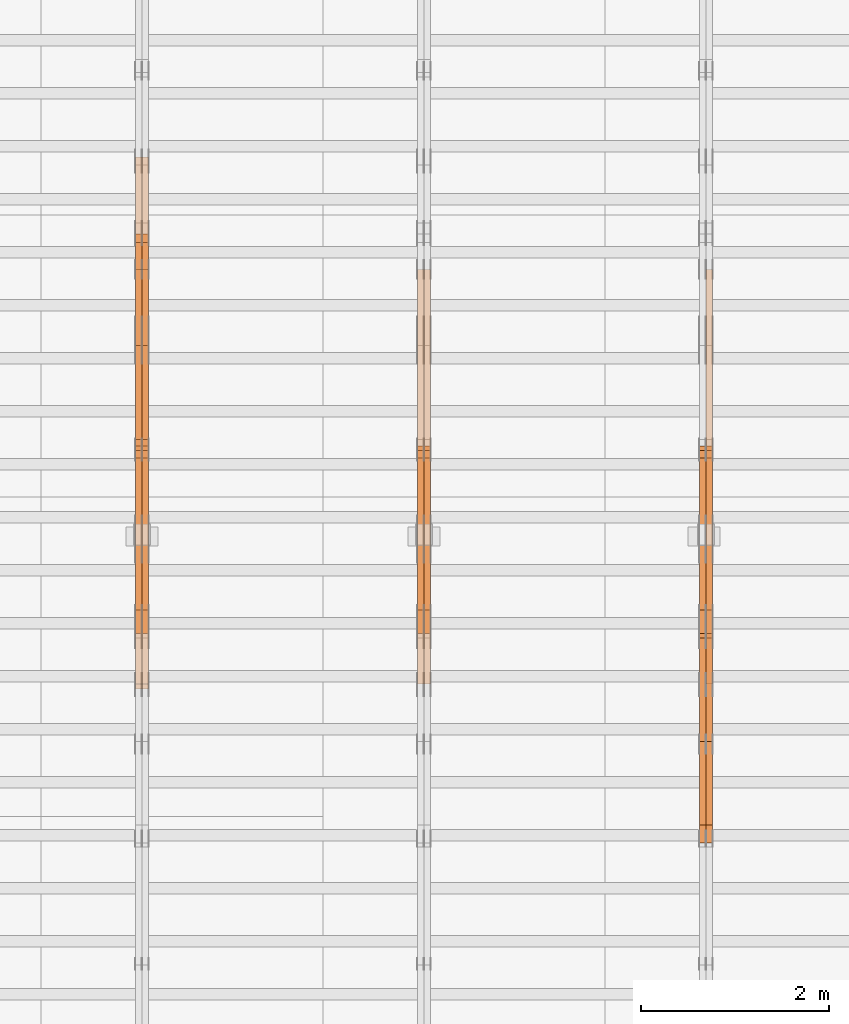
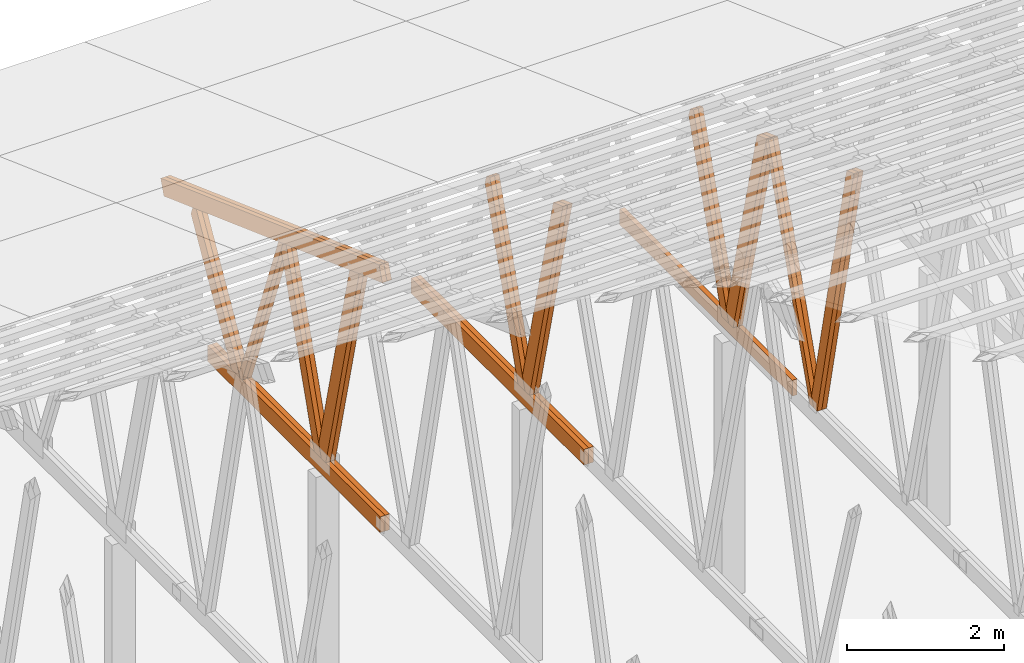
# One storey, part 41 of 189: 27 proxies.
"""IFC2X3 building model written with IfcOpenShell, lengths in millimetres."""

from ifc_helpers import new_model, entity, si_unit, converted_unit, derived_unit, direction, frame, origin, origin_2d_with_axis, place, context, subcontext, project, spatial, polyline, rectangle, outline, extrude, source, transform, mapped, material, type_object, type_shapes, element, save


model = new_model("IFC2X3")

# Units and contexts
model_context = context("Model", 3, precision=0.01, world=origin(), true_north=direction((6.12303176911189e-17, 1.0)))
body_context = subcontext(model_context, "Body", "Model", "MODEL_VIEW")
ifc_project = project(units=[si_unit("LENGTHUNIT", "METRE", prefix="MILLI"), si_unit("AREAUNIT", "SQUARE_METRE"), si_unit("VOLUMEUNIT", "CUBIC_METRE"), converted_unit("PLANEANGLEUNIT", "DEGREE", entity("IfcRatioMeasure", 0.0174532925199433), si_unit("PLANEANGLEUNIT", "RADIAN"), dimensions=[0, 0, 0, 0, 0, 0, 0]), si_unit("MASSUNIT", "GRAM", prefix="KILO"), derived_unit("MASSDENSITYUNIT", [(si_unit("MASSUNIT", "GRAM", prefix="KILO"), 1), (si_unit("LENGTHUNIT", "METRE"), -3)]), si_unit("TIMEUNIT", "SECOND"), si_unit("FREQUENCYUNIT", "HERTZ"), si_unit("THERMODYNAMICTEMPERATUREUNIT", "DEGREE_CELSIUS"), derived_unit("THERMALTRANSMITTANCEUNIT", [(si_unit("MASSUNIT", "GRAM", prefix="KILO"), 1), (si_unit("THERMODYNAMICTEMPERATUREUNIT", "KELVIN"), -1), (si_unit("TIMEUNIT", "SECOND"), -3)]), derived_unit("VOLUMETRICFLOWRATEUNIT", [(si_unit("LENGTHUNIT", "METRE"), 3), (si_unit("TIMEUNIT", "SECOND"), -1)]), si_unit("ELECTRICCURRENTUNIT", "AMPERE"), si_unit("ELECTRICVOLTAGEUNIT", "VOLT"), si_unit("POWERUNIT", "WATT"), si_unit("FORCEUNIT", "NEWTON"), si_unit("ILLUMINANCEUNIT", "LUX"), si_unit("LUMINOUSFLUXUNIT", "LUMEN"), si_unit("LUMINOUSINTENSITYUNIT", "CANDELA"), derived_unit("USERDEFINED", [(si_unit("MASSUNIT", "GRAM", prefix="KILO"), -1), (si_unit("LENGTHUNIT", "METRE"), -2), (si_unit("TIMEUNIT", "SECOND"), 3), (si_unit("LUMINOUSFLUXUNIT", "LUMEN"), 1)]), derived_unit("LINEARVELOCITYUNIT", [(si_unit("LENGTHUNIT", "METRE"), 1), (si_unit("TIMEUNIT", "SECOND"), -1)]), si_unit("PRESSUREUNIT", "PASCAL"), derived_unit("USERDEFINED", [(si_unit("LENGTHUNIT", "METRE"), -2), (si_unit("MASSUNIT", "GRAM", prefix="KILO"), 1), (si_unit("TIMEUNIT", "SECOND"), -2)])], contexts=[model_context])

# Site, building, storey
site_placement = place(None, origin())
site = spatial("IfcSite", under=ifc_project, at=site_placement, CompositionType="ELEMENT")
building_placement = place(site_placement, origin())
building = spatial("IfcBuilding", under=site, at=building_placement, CompositionType="ELEMENT")
storey_placement = place(building_placement, origin())
storey = spatial("IfcBuildingStorey", under=building, at=storey_placement, Name="Default", CompositionType="ELEMENT", Elevation=0.0)

# Proxies
ifc_material_1 = material(Name="IfcSurfaceStyle #162714")
building_element_proxy_type_1 = type_object("IfcBuildingElementProxyType", Name="T1-W3 162712", PredefinedType="NOTDEFINED", material=ifc_material_1)
shared_shape_1 = source(origin(), body_context, "Body", "SweptSolid", [
    extrude(outline(polyline([(-2517.58938959787, -85.0001104675026), (1625.445846867, -85.0001104675027), (1768.20563426494, 0.000209440697654673), (1749.48871563991, 85.0000057471538), (-2625.55080717397, 85.0000057471538), (-2517.58938959787, -85.0001104675026)])), frame((1768.2056683344, 85.0000547211315, 0.0), z_axis=(0.0, 0.0, 1.0), x_axis=(-1.0, 0.0, 0.0)), (0.0, 0.0, 1.0), 69.9999999999997),
])
type_shapes(building_element_proxy_type_1, [shared_shape_1])
proxy_1_placement = place(building_placement, frame((30300.0, 18415.3042863408, 226.720947016584), z_axis=(-1.0, 0.0, 0.0), x_axis=(0.0, -0.215047682154604, 0.976603550269982)))
element("IfcBuildingElementProxy", 1, at=proxy_1_placement, inside=storey, type_object=building_element_proxy_type_1, material=ifc_material_1, Name="T1-W3", context=body_context, shape_type="MappedRepresentation", body=[
    mapped(shared_shape_1, transform((0.0, 0.0, 0.0), scale=1.0)),
])
ifc_material_2 = material(Name="IfcSurfaceStyle #162648")
building_element_proxy_type_2 = type_object("IfcBuildingElementProxyType", Name="T1-W3 162646", PredefinedType="NOTDEFINED", material=ifc_material_2)
shared_shape_2 = source(origin(), body_context, "Body", "SweptSolid", [
    extrude(outline(polyline([(-2517.58938959787, -85.0001104675026), (1625.445846867, -85.0001104675027), (1768.20563426494, 0.000209440697654673), (1749.48871563991, 85.0000057471538), (-2625.55080717397, 85.0000057471538), (-2517.58938959787, -85.0001104675026)])), frame((1768.2056683344, 85.0000547211315, 0.0), z_axis=(0.0, 0.0, 1.0), x_axis=(-1.0, 0.0, 0.0)), (0.0, 0.0, 1.0), 69.9999999999997),
])
type_shapes(building_element_proxy_type_2, [shared_shape_2])
proxy_2_placement = place(building_placement, frame((30230.0, 18415.3042863408, 226.720947016584), z_axis=(-1.0, 0.0, 0.0), x_axis=(0.0, -0.215047682154604, 0.976603550269982)))
element("IfcBuildingElementProxy", 2, at=proxy_2_placement, inside=storey, type_object=building_element_proxy_type_2, material=ifc_material_2, Name="T1-W3", context=body_context, shape_type="MappedRepresentation", body=[
    mapped(shared_shape_2, transform((0.0, 0.0, 0.0), scale=1.0)),
])
ifc_material_3 = material(Name="IfcSurfaceStyle #162450")
building_element_proxy_type_3 = type_object("IfcBuildingElementProxyType", Name="T1-W7 162448", PredefinedType="NOTDEFINED", material=ifc_material_3)
shared_shape_3 = source(origin(), body_context, "Body", "SweptSolid", [
    extrude(outline(polyline([(-2189.6662270939, -47.5000140805343), (1475.30081553583, -47.5000140805343), (1473.93388518462, 0.00042343352179337), (1398.58463533215, 47.4998023637734), (-2158.15310895869, 47.4998023637734), (-2189.6662270939, -47.5000140805343)])), frame((1475.30081553583, 47.5004895824757, 0.0), z_axis=(0.0, 0.0, 1.0), x_axis=(-1.0, 0.0, 0.0)), (0.0, 0.0, 1.0), 69.9999999999998),
])
type_shapes(building_element_proxy_type_3, [shared_shape_3])
proxy_3_placement = place(building_placement, frame((30300.0, 19742.3819153401, 3693.66743808885), z_axis=(-1.0, 0.0, 0.0), x_axis=(0.0, -0.314845237923104, -0.949143021971475)))
element("IfcBuildingElementProxy", 3, at=proxy_3_placement, inside=storey, type_object=building_element_proxy_type_3, material=ifc_material_3, Name="T1-W7", context=body_context, shape_type="MappedRepresentation", body=[
    mapped(shared_shape_3, transform((0.0, 0.0, 0.0), scale=1.0)),
])
ifc_material_4 = material(Name="IfcSurfaceStyle #162384")
building_element_proxy_type_4 = type_object("IfcBuildingElementProxyType", Name="T1-W7 162382", PredefinedType="NOTDEFINED", material=ifc_material_4)
shared_shape_4 = source(origin(), body_context, "Body", "SweptSolid", [
    extrude(outline(polyline([(-2189.6662270939, -47.5000140805343), (1475.30081553583, -47.5000140805343), (1473.93388518462, 0.00042343352179337), (1398.58463533215, 47.4998023637734), (-2158.15310895869, 47.4998023637734), (-2189.6662270939, -47.5000140805343)])), frame((1475.30081553583, 47.5004895824757, 0.0), z_axis=(0.0, 0.0, 1.0), x_axis=(-1.0, 0.0, 0.0)), (0.0, 0.0, 1.0), 69.9999999999998),
])
type_shapes(building_element_proxy_type_4, [shared_shape_4])
proxy_4_placement = place(building_placement, frame((30230.0, 19742.3819153401, 3693.66743808885), z_axis=(-1.0, 0.0, 0.0), x_axis=(0.0, -0.314845237923104, -0.949143021971475)))
element("IfcBuildingElementProxy", 4, at=proxy_4_placement, inside=storey, type_object=building_element_proxy_type_4, material=ifc_material_4, Name="T1-W7", context=body_context, shape_type="MappedRepresentation", body=[
    mapped(shared_shape_4, transform((0.0, 0.0, 0.0), scale=1.0)),
])
ifc_material_5 = material(Name="IfcSurfaceStyle #162186")
building_element_proxy_type_5 = type_object("IfcBuildingElementProxyType", Name="T1-W1 162184", PredefinedType="NOTDEFINED", material=ifc_material_5)
shared_shape_5 = source(origin(), body_context, "Body", "SweptSolid", [
    extrude(outline(polyline([(-1996.99427801396, -109.999889649051), (1271.09905152223, -109.999889649051), (1448.88120817726, -0.000113190727324008), (1421.70802776002, 109.999946244415), (-2144.69400944554, 109.999946244415), (-1996.99427801396, -109.999889649051)])), frame((1448.88120817726, 110.000265670598, 0.0), z_axis=(0.0, 0.0, 1.0), x_axis=(-1.0, 0.0, 0.0)), (0.0, 0.0, 1.0), 69.9999999999998),
])
type_shapes(building_element_proxy_type_5, [shared_shape_5])
proxy_5_placement = place(building_placement, frame((30300.0, 20558.6774904859, 218.61972674968), z_axis=(-1.0, 0.0, 0.0), x_axis=(0.0, -0.239819839925979, 0.970817410421691)))
element("IfcBuildingElementProxy", 5, at=proxy_5_placement, inside=storey, type_object=building_element_proxy_type_5, material=ifc_material_5, Name="T1-W1", context=body_context, shape_type="MappedRepresentation", body=[
    mapped(shared_shape_5, transform((0.0, 0.0, 0.0), scale=1.0)),
])
ifc_material_6 = material(Name="IfcSurfaceStyle #162120")
building_element_proxy_type_6 = type_object("IfcBuildingElementProxyType", Name="T1-W1 162118", PredefinedType="NOTDEFINED", material=ifc_material_6)
shared_shape_6 = source(origin(), body_context, "Body", "SweptSolid", [
    extrude(outline(polyline([(-1996.99427801396, -109.999889649051), (1271.09905152223, -109.999889649051), (1448.88120817726, -0.000113190727324008), (1421.70802776002, 109.999946244415), (-2144.69400944554, 109.999946244415), (-1996.99427801396, -109.999889649051)])), frame((1448.88120817726, 110.000265670598, 0.0), z_axis=(0.0, 0.0, 1.0), x_axis=(-1.0, 0.0, 0.0)), (0.0, 0.0, 1.0), 69.9999999999998),
])
type_shapes(building_element_proxy_type_6, [shared_shape_6])
proxy_6_placement = place(building_placement, frame((30230.0, 20558.6774904859, 218.61972674968), z_axis=(-1.0, 0.0, 0.0), x_axis=(0.0, -0.239819839925979, 0.970817410421691)))
element("IfcBuildingElementProxy", 6, at=proxy_6_placement, inside=storey, type_object=building_element_proxy_type_6, material=ifc_material_6, Name="T1-W1", context=body_context, shape_type="MappedRepresentation", body=[
    mapped(shared_shape_6, transform((0.0, 0.0, 0.0), scale=1.0)),
])
ifc_material_7 = material(Name="IfcSurfaceStyle #161922")
building_element_proxy_type_7 = type_object("IfcBuildingElementProxyType", Name="T1-W4 161920", PredefinedType="NOTDEFINED", material=ifc_material_7)
shared_shape_7 = source(origin(), body_context, "Body", "SweptSolid", [
    extrude(outline(polyline([(-1742.90513395849, -84.9997422414737), (1181.3544167489, -84.9997422414737), (1178.19398821251, -0.000208932978430543), (1071.44989130457, 84.999846707963), (-1688.09316230749, 84.999846707963), (-1742.90513395849, -84.9997422414737)])), frame((1181.35452116422, 84.999886337523, 0.0), z_axis=(0.0, 0.0, 1.0), x_axis=(-1.0, 0.0, 0.0)), (0.0, 0.0, 1.0), 69.9999999999998),
])
type_shapes(building_element_proxy_type_7, [shared_shape_7])
proxy_7_placement = place(building_placement, frame((30300.0, 21724.6281517871, 2976.00232464744), z_axis=(-1.0, 0.0, 0.0), x_axis=(0.0, -0.306868406216495, -0.951751953644514)))
element("IfcBuildingElementProxy", 7, at=proxy_7_placement, inside=storey, type_object=building_element_proxy_type_7, material=ifc_material_7, Name="T1-W4", context=body_context, shape_type="MappedRepresentation", body=[
    mapped(shared_shape_7, transform((0.0, 0.0, 0.0), scale=1.0)),
])
ifc_material_8 = material(Name="IfcSurfaceStyle #161856")
building_element_proxy_type_8 = type_object("IfcBuildingElementProxyType", Name="T1-W4 161854", PredefinedType="NOTDEFINED", material=ifc_material_8)
shared_shape_8 = source(origin(), body_context, "Body", "SweptSolid", [
    extrude(outline(polyline([(-1742.90513395849, -84.9997422414737), (1181.3544167489, -84.9997422414737), (1178.19398821251, -0.000208932978430543), (1071.44989130457, 84.999846707963), (-1688.09316230749, 84.999846707963), (-1742.90513395849, -84.9997422414737)])), frame((1181.35452116422, 84.999886337523, 0.0), z_axis=(0.0, 0.0, 1.0), x_axis=(-1.0, 0.0, 0.0)), (0.0, 0.0, 1.0), 69.9999999999998),
])
type_shapes(building_element_proxy_type_8, [shared_shape_8])
proxy_8_placement = place(building_placement, frame((30230.0, 21724.6281517871, 2976.00232464744), z_axis=(-1.0, 0.0, 0.0), x_axis=(0.0, -0.306868406216495, -0.951751953644514)))
element("IfcBuildingElementProxy", 8, at=proxy_8_placement, inside=storey, type_object=building_element_proxy_type_8, material=ifc_material_8, Name="T1-W4", context=body_context, shape_type="MappedRepresentation", body=[
    mapped(shared_shape_8, transform((0.0, 0.0, 0.0), scale=1.0)),
])
ifc_material_9 = material(Name="IfcSurfaceStyle #159318")
building_element_proxy_type_9 = type_object("IfcBuildingElementProxyType", Name="T1-B4 159316", PredefinedType="NOTDEFINED", material=ifc_material_9)
shared_shape_9 = source(origin(), body_context, "Body", "SweptSolid", [
    extrude(rectangle(XDim=4408.2412109375, YDim=245.000000000001, at=origin_2d_with_axis()), frame((2204.12060546875, 122.5, 0.0), z_axis=(0.0, 0.0, 1.0), x_axis=(-1.0, 0.0, 0.0)), (0.0, 0.0, 1.0), 69.9999999999997),
])
type_shapes(building_element_proxy_type_9, [shared_shape_9])
proxy_9_placement = place(building_placement, frame((30300.0, 19161.7587890625, 245.0), z_axis=(-1.0, 0.0, 0.0), x_axis=(0.0, 1.0, 0.0)))
element("IfcBuildingElementProxy", 9, at=proxy_9_placement, inside=storey, type_object=building_element_proxy_type_9, material=ifc_material_9, Name="T1-B4", context=body_context, shape_type="MappedRepresentation", body=[
    mapped(shared_shape_9, transform((0.0, 0.0, 0.0), scale=1.0)),
])
ifc_material_10 = material(Name="IfcSurfaceStyle #146396")
building_element_proxy_type_10 = type_object("IfcBuildingElementProxyType", Name="T1-W1 146394", PredefinedType="NOTDEFINED", material=ifc_material_10)
shared_shape_10 = source(origin(), body_context, "Body", "SweptSolid", [
    extrude(outline(polyline([(-1996.99427801396, -109.999889649051), (1271.09905152223, -109.999889649051), (1448.88120817726, -0.000113190727324008), (1421.70802776002, 109.999946244415), (-2144.69400944554, 109.999946244415), (-1996.99427801396, -109.999889649051)])), frame((1448.88120817726, 110.000265670598, 0.0), z_axis=(0.0, 0.0, 1.0), x_axis=(-1.0, 0.0, 0.0)), (0.0, 0.0, 1.0), 69.9999999999998),
])
type_shapes(building_element_proxy_type_10, [shared_shape_10])
proxy_10_placement = place(building_placement, frame((27300.0, 20558.6774904859, 218.61972674968), z_axis=(-1.0, 0.0, 0.0), x_axis=(0.0, -0.239819839925979, 0.970817410421691)))
element("IfcBuildingElementProxy", 10, at=proxy_10_placement, inside=storey, type_object=building_element_proxy_type_10, material=ifc_material_10, Name="T1-W1", context=body_context, shape_type="MappedRepresentation", body=[
    mapped(shared_shape_10, transform((0.0, 0.0, 0.0), scale=1.0)),
])
ifc_material_11 = material(Name="IfcSurfaceStyle #146330")
building_element_proxy_type_11 = type_object("IfcBuildingElementProxyType", Name="T1-W1 146328", PredefinedType="NOTDEFINED", material=ifc_material_11)
shared_shape_11 = source(origin(), body_context, "Body", "SweptSolid", [
    extrude(outline(polyline([(-1996.99427801396, -109.999889649051), (1271.09905152223, -109.999889649051), (1448.88120817726, -0.000113190727324008), (1421.70802776002, 109.999946244415), (-2144.69400944554, 109.999946244415), (-1996.99427801396, -109.999889649051)])), frame((1448.88120817726, 110.000265670598, 0.0), z_axis=(0.0, 0.0, 1.0), x_axis=(-1.0, 0.0, 0.0)), (0.0, 0.0, 1.0), 69.9999999999998),
])
type_shapes(building_element_proxy_type_11, [shared_shape_11])
proxy_11_placement = place(building_placement, frame((27230.0, 20558.6774904859, 218.61972674968), z_axis=(-1.0, 0.0, 0.0), x_axis=(0.0, -0.239819839925979, 0.970817410421691)))
element("IfcBuildingElementProxy", 11, at=proxy_11_placement, inside=storey, type_object=building_element_proxy_type_11, material=ifc_material_11, Name="T1-W1", context=body_context, shape_type="MappedRepresentation", body=[
    mapped(shared_shape_11, transform((0.0, 0.0, 0.0), scale=1.0)),
])
ifc_material_12 = material(Name="IfcSurfaceStyle #146132")
building_element_proxy_type_12 = type_object("IfcBuildingElementProxyType", Name="T1-W4 146130", PredefinedType="NOTDEFINED", material=ifc_material_12)
shared_shape_12 = source(origin(), body_context, "Body", "SweptSolid", [
    extrude(outline(polyline([(-1742.90513395849, -84.9997422414737), (1181.3544167489, -84.9997422414737), (1178.19398821251, -0.000208932978430543), (1071.44989130457, 84.999846707963), (-1688.09316230749, 84.999846707963), (-1742.90513395849, -84.9997422414737)])), frame((1181.35452116422, 84.999886337523, 0.0), z_axis=(0.0, 0.0, 1.0), x_axis=(-1.0, 0.0, 0.0)), (0.0, 0.0, 1.0), 69.9999999999998),
])
type_shapes(building_element_proxy_type_12, [shared_shape_12])
proxy_12_placement = place(building_placement, frame((27300.0, 21724.6281517871, 2976.00232464744), z_axis=(-1.0, 0.0, 0.0), x_axis=(0.0, -0.306868406216495, -0.951751953644514)))
element("IfcBuildingElementProxy", 12, at=proxy_12_placement, inside=storey, type_object=building_element_proxy_type_12, material=ifc_material_12, Name="T1-W4", context=body_context, shape_type="MappedRepresentation", body=[
    mapped(shared_shape_12, transform((0.0, 0.0, 0.0), scale=1.0)),
])
ifc_material_13 = material(Name="IfcSurfaceStyle #146066")
building_element_proxy_type_13 = type_object("IfcBuildingElementProxyType", Name="T1-W4 146064", PredefinedType="NOTDEFINED", material=ifc_material_13)
shared_shape_13 = source(origin(), body_context, "Body", "SweptSolid", [
    extrude(outline(polyline([(-1742.90513395849, -84.9997422414737), (1181.3544167489, -84.9997422414737), (1178.19398821251, -0.000208932978430543), (1071.44989130457, 84.999846707963), (-1688.09316230749, 84.999846707963), (-1742.90513395849, -84.9997422414737)])), frame((1181.35452116422, 84.999886337523, 0.0), z_axis=(0.0, 0.0, 1.0), x_axis=(-1.0, 0.0, 0.0)), (0.0, 0.0, 1.0), 69.9999999999998),
])
type_shapes(building_element_proxy_type_13, [shared_shape_13])
proxy_13_placement = place(building_placement, frame((27230.0, 21724.6281517871, 2976.00232464744), z_axis=(-1.0, 0.0, 0.0), x_axis=(0.0, -0.306868406216495, -0.951751953644514)))
element("IfcBuildingElementProxy", 13, at=proxy_13_placement, inside=storey, type_object=building_element_proxy_type_13, material=ifc_material_13, Name="T1-W4", context=body_context, shape_type="MappedRepresentation", body=[
    mapped(shared_shape_13, transform((0.0, 0.0, 0.0), scale=1.0)),
])
ifc_material_14 = material(Name="IfcSurfaceStyle #143528")
building_element_proxy_type_14 = type_object("IfcBuildingElementProxyType", Name="T1-B4 143526", PredefinedType="NOTDEFINED", material=ifc_material_14)
shared_shape_14 = source(origin(), body_context, "Body", "SweptSolid", [
    extrude(rectangle(XDim=4408.2412109375, YDim=245.000000000001, at=origin_2d_with_axis()), frame((2204.12060546875, 122.5, 0.0), z_axis=(0.0, 0.0, 1.0), x_axis=(-1.0, 0.0, 0.0)), (0.0, 0.0, 1.0), 69.9999999999997),
])
type_shapes(building_element_proxy_type_14, [shared_shape_14])
proxy_14_placement = place(building_placement, frame((27300.0, 19161.7587890625, 245.0), z_axis=(-1.0, 0.0, 0.0), x_axis=(0.0, 1.0, 0.0)))
element("IfcBuildingElementProxy", 14, at=proxy_14_placement, inside=storey, type_object=building_element_proxy_type_14, material=ifc_material_14, Name="T1-B4", context=body_context, shape_type="MappedRepresentation", body=[
    mapped(shared_shape_14, transform((0.0, 0.0, 0.0), scale=1.0)),
])
ifc_material_15 = material(Name="IfcSurfaceStyle #143471")
building_element_proxy_type_15 = type_object("IfcBuildingElementProxyType", Name="T1-B4 143469", PredefinedType="NOTDEFINED", material=ifc_material_15)
shared_shape_15 = source(origin(), body_context, "Body", "SweptSolid", [
    extrude(rectangle(XDim=4408.2412109375, YDim=245.000000000001, at=origin_2d_with_axis()), frame((2204.12060546875, 122.5, 0.0), z_axis=(0.0, 0.0, 1.0), x_axis=(-1.0, 0.0, 0.0)), (0.0, 0.0, 1.0), 69.9999999999997),
])
type_shapes(building_element_proxy_type_15, [shared_shape_15])
proxy_15_placement = place(building_placement, frame((27230.0, 19161.7587890625, 245.0), z_axis=(-1.0, 0.0, 0.0), x_axis=(0.0, 1.0, 0.0)))
element("IfcBuildingElementProxy", 15, at=proxy_15_placement, inside=storey, type_object=building_element_proxy_type_15, material=ifc_material_15, Name="T1-B4", context=body_context, shape_type="MappedRepresentation", body=[
    mapped(shared_shape_15, transform((0.0, 0.0, 0.0), scale=1.0)),
])
ifc_material_16 = material(Name="IfcSurfaceStyle #130606")
building_element_proxy_type_16 = type_object("IfcBuildingElementProxyType", Name="T1-W1 130604", PredefinedType="NOTDEFINED", material=ifc_material_16)
shared_shape_16 = source(origin(), body_context, "Body", "SweptSolid", [
    extrude(outline(polyline([(-1996.99427801396, -109.999889649051), (1271.09905152223, -109.999889649051), (1448.88120817726, -0.000113190727324008), (1421.70802776002, 109.999946244415), (-2144.69400944554, 109.999946244415), (-1996.99427801396, -109.999889649051)])), frame((1448.88120817726, 110.000265670598, 0.0), z_axis=(0.0, 0.0, 1.0), x_axis=(-1.0, 0.0, 0.0)), (0.0, 0.0, 1.0), 69.9999999999998),
])
type_shapes(building_element_proxy_type_16, [shared_shape_16])
proxy_16_placement = place(building_placement, frame((24300.0, 20558.6774904859, 218.61972674968), z_axis=(-1.0, 0.0, 0.0), x_axis=(0.0, -0.239819839925979, 0.970817410421691)))
element("IfcBuildingElementProxy", 16, at=proxy_16_placement, inside=storey, type_object=building_element_proxy_type_16, material=ifc_material_16, Name="T1-W1", context=body_context, shape_type="MappedRepresentation", body=[
    mapped(shared_shape_16, transform((0.0, 0.0, 0.0), scale=1.0)),
])
ifc_material_17 = material(Name="IfcSurfaceStyle #130540")
building_element_proxy_type_17 = type_object("IfcBuildingElementProxyType", Name="T1-W1 130538", PredefinedType="NOTDEFINED", material=ifc_material_17)
shared_shape_17 = source(origin(), body_context, "Body", "SweptSolid", [
    extrude(outline(polyline([(-1996.99427801396, -109.999889649051), (1271.09905152223, -109.999889649051), (1448.88120817726, -0.000113190727324008), (1421.70802776002, 109.999946244415), (-2144.69400944554, 109.999946244415), (-1996.99427801396, -109.999889649051)])), frame((1448.88120817726, 110.000265670598, 0.0), z_axis=(0.0, 0.0, 1.0), x_axis=(-1.0, 0.0, 0.0)), (0.0, 0.0, 1.0), 69.9999999999998),
])
type_shapes(building_element_proxy_type_17, [shared_shape_17])
proxy_17_placement = place(building_placement, frame((24230.0, 20558.6774904859, 218.61972674968), z_axis=(-1.0, 0.0, 0.0), x_axis=(0.0, -0.239819839925979, 0.970817410421691)))
element("IfcBuildingElementProxy", 17, at=proxy_17_placement, inside=storey, type_object=building_element_proxy_type_17, material=ifc_material_17, Name="T1-W1", context=body_context, shape_type="MappedRepresentation", body=[
    mapped(shared_shape_17, transform((0.0, 0.0, 0.0), scale=1.0)),
])
ifc_material_18 = material(Name="IfcSurfaceStyle #130342")
building_element_proxy_type_18 = type_object("IfcBuildingElementProxyType", Name="T1-W4 130340", PredefinedType="NOTDEFINED", material=ifc_material_18)
shared_shape_18 = source(origin(), body_context, "Body", "SweptSolid", [
    extrude(outline(polyline([(-1742.90513395849, -84.9997422414737), (1181.3544167489, -84.9997422414737), (1178.19398821251, -0.000208932978430543), (1071.44989130457, 84.999846707963), (-1688.09316230749, 84.999846707963), (-1742.90513395849, -84.9997422414737)])), frame((1181.35452116422, 84.999886337523, 0.0), z_axis=(0.0, 0.0, 1.0), x_axis=(-1.0, 0.0, 0.0)), (0.0, 0.0, 1.0), 69.9999999999998),
])
type_shapes(building_element_proxy_type_18, [shared_shape_18])
proxy_18_placement = place(building_placement, frame((24300.0, 21724.6281517871, 2976.00232464744), z_axis=(-1.0, 0.0, 0.0), x_axis=(0.0, -0.306868406216495, -0.951751953644514)))
element("IfcBuildingElementProxy", 18, at=proxy_18_placement, inside=storey, type_object=building_element_proxy_type_18, material=ifc_material_18, Name="T1-W4", context=body_context, shape_type="MappedRepresentation", body=[
    mapped(shared_shape_18, transform((0.0, 0.0, 0.0), scale=1.0)),
])
ifc_material_19 = material(Name="IfcSurfaceStyle #130276")
building_element_proxy_type_19 = type_object("IfcBuildingElementProxyType", Name="T1-W4 130274", PredefinedType="NOTDEFINED", material=ifc_material_19)
shared_shape_19 = source(origin(), body_context, "Body", "SweptSolid", [
    extrude(outline(polyline([(-1742.90513395849, -84.9997422414737), (1181.3544167489, -84.9997422414737), (1178.19398821251, -0.000208932978430543), (1071.44989130457, 84.999846707963), (-1688.09316230749, 84.999846707963), (-1742.90513395849, -84.9997422414737)])), frame((1181.35452116422, 84.999886337523, 0.0), z_axis=(0.0, 0.0, 1.0), x_axis=(-1.0, 0.0, 0.0)), (0.0, 0.0, 1.0), 69.9999999999998),
])
type_shapes(building_element_proxy_type_19, [shared_shape_19])
proxy_19_placement = place(building_placement, frame((24230.0, 21724.6281517871, 2976.00232464744), z_axis=(-1.0, 0.0, 0.0), x_axis=(0.0, -0.306868406216495, -0.951751953644514)))
element("IfcBuildingElementProxy", 19, at=proxy_19_placement, inside=storey, type_object=building_element_proxy_type_19, material=ifc_material_19, Name="T1-W4", context=body_context, shape_type="MappedRepresentation", body=[
    mapped(shared_shape_19, transform((0.0, 0.0, 0.0), scale=1.0)),
])
ifc_material_20 = material(Name="IfcSurfaceStyle #130078")
building_element_proxy_type_20 = type_object("IfcBuildingElementProxyType", Name="T1-W8 130076", PredefinedType="NOTDEFINED", material=ifc_material_20)
shared_shape_20 = source(origin(), body_context, "Body", "SweptSolid", [
    extrude(outline(polyline([(-1700.10906247918, -47.4998559987011), (1140.60243146647, -47.4998559987011), (1179.56122089033, 0.000120838919977206), (1161.65086478184, 47.4997955792411), (-1781.70545465947, 47.4997955792411), (-1700.10906247918, -47.4998559987011)])), frame((1179.56128464708, 47.5000634692093, 0.0), z_axis=(0.0, 0.0, 1.0), x_axis=(-1.0, 0.0, 0.0)), (0.0, 0.0, 1.0), 69.9999999999998),
])
type_shapes(building_element_proxy_type_20, [shared_shape_20])
proxy_20_placement = place(building_placement, frame((24300.0, 22687.5385403115, 228.241249073207), z_axis=(-1.0, 0.0, 0.0), x_axis=(0.0, -0.352814979177604, 0.93569310698963)))
element("IfcBuildingElementProxy", 20, at=proxy_20_placement, inside=storey, type_object=building_element_proxy_type_20, material=ifc_material_20, Name="T1-W8", context=body_context, shape_type="MappedRepresentation", body=[
    mapped(shared_shape_20, transform((0.0, 0.0, 0.0), scale=1.0)),
])
ifc_material_21 = material(Name="IfcSurfaceStyle #130012")
building_element_proxy_type_21 = type_object("IfcBuildingElementProxyType", Name="T1-W8 130010", PredefinedType="NOTDEFINED", material=ifc_material_21)
shared_shape_21 = source(origin(), body_context, "Body", "SweptSolid", [
    extrude(outline(polyline([(-1700.10906247918, -47.4998559987011), (1140.60243146647, -47.4998559987011), (1179.56122089033, 0.000120838919977206), (1161.65086478184, 47.4997955792411), (-1781.70545465947, 47.4997955792411), (-1700.10906247918, -47.4998559987011)])), frame((1179.56128464708, 47.5000634692093, 0.0), z_axis=(0.0, 0.0, 1.0), x_axis=(-1.0, 0.0, 0.0)), (0.0, 0.0, 1.0), 69.9999999999998),
])
type_shapes(building_element_proxy_type_21, [shared_shape_21])
proxy_21_placement = place(building_placement, frame((24230.0, 22687.5385403115, 228.241249073207), z_axis=(-1.0, 0.0, 0.0), x_axis=(0.0, -0.352814979177604, 0.93569310698963)))
element("IfcBuildingElementProxy", 21, at=proxy_21_placement, inside=storey, type_object=building_element_proxy_type_21, material=ifc_material_21, Name="T1-W8", context=body_context, shape_type="MappedRepresentation", body=[
    mapped(shared_shape_21, transform((0.0, 0.0, 0.0), scale=1.0)),
])
ifc_material_22 = material(Name="IfcSurfaceStyle #129814")
building_element_proxy_type_22 = type_object("IfcBuildingElementProxyType", Name="T1-W2 129812", PredefinedType="NOTDEFINED", material=ifc_material_22)
shared_shape_22 = source(origin(), body_context, "Body", "SweptSolid", [
    extrude(outline(polyline([(-1361.89144606429, -97.5000598486876), (887.613245225805, -97.5000598486876), (904.774262962339, 0.000302345139042259), (818.892339969004, 97.4999086761182), (-1249.38840209286, 97.4999086761182), (-1361.89144606429, -97.5000598486876)])), frame((904.774262962339, 97.5000966763391, 0.0), z_axis=(0.0, 0.0, 1.0), x_axis=(-1.0, 0.0, 0.0)), (0.0, 0.0, 1.0), 69.9999999999999),
])
type_shapes(building_element_proxy_type_22, [shared_shape_22])
proxy_22_placement = place(building_placement, frame((24300.0, 24033.6159173732, 2110.89189244614), z_axis=(-1.0, 0.0, 0.0), x_axis=(0.0, -0.5, -0.866025403784439)))
element("IfcBuildingElementProxy", 22, at=proxy_22_placement, inside=storey, type_object=building_element_proxy_type_22, material=ifc_material_22, Name="T1-W2", context=body_context, shape_type="MappedRepresentation", body=[
    mapped(shared_shape_22, transform((0.0, 0.0, 0.0), scale=1.0)),
])
ifc_material_23 = material(Name="IfcSurfaceStyle #129748")
building_element_proxy_type_23 = type_object("IfcBuildingElementProxyType", Name="T1-W2 129746", PredefinedType="NOTDEFINED", material=ifc_material_23)
shared_shape_23 = source(origin(), body_context, "Body", "SweptSolid", [
    extrude(outline(polyline([(-1361.89144606429, -97.5000598486876), (887.613245225805, -97.5000598486876), (904.774262962339, 0.000302345139042259), (818.892339969004, 97.4999086761182), (-1249.38840209286, 97.4999086761182), (-1361.89144606429, -97.5000598486876)])), frame((904.774262962339, 97.5000966763391, 0.0), z_axis=(0.0, 0.0, 1.0), x_axis=(-1.0, 0.0, 0.0)), (0.0, 0.0, 1.0), 69.9999999999999),
])
type_shapes(building_element_proxy_type_23, [shared_shape_23])
proxy_23_placement = place(building_placement, frame((24230.0, 24033.6159173732, 2110.89189244614), z_axis=(-1.0, 0.0, 0.0), x_axis=(0.0, -0.5, -0.866025403784439)))
element("IfcBuildingElementProxy", 23, at=proxy_23_placement, inside=storey, type_object=building_element_proxy_type_23, material=ifc_material_23, Name="T1-W2", context=body_context, shape_type="MappedRepresentation", body=[
    mapped(shared_shape_23, transform((0.0, 0.0, 0.0), scale=1.0)),
])
ifc_material_24 = material(Name="IfcSurfaceStyle #127738")
building_element_proxy_type_24 = type_object("IfcBuildingElementProxyType", Name="T1-B4 127736", PredefinedType="NOTDEFINED", material=ifc_material_24)
shared_shape_24 = source(origin(), body_context, "Body", "SweptSolid", [
    extrude(rectangle(XDim=4408.2412109375, YDim=245.000000000001, at=origin_2d_with_axis()), frame((2204.12060546875, 122.5, 0.0), z_axis=(0.0, 0.0, 1.0), x_axis=(-1.0, 0.0, 0.0)), (0.0, 0.0, 1.0), 69.9999999999997),
])
type_shapes(building_element_proxy_type_24, [shared_shape_24])
proxy_24_placement = place(building_placement, frame((24300.0, 19161.7587890625, 245.0), z_axis=(-1.0, 0.0, 0.0), x_axis=(0.0, 1.0, 0.0)))
element("IfcBuildingElementProxy", 24, at=proxy_24_placement, inside=storey, type_object=building_element_proxy_type_24, material=ifc_material_24, Name="T1-B4", context=body_context, shape_type="MappedRepresentation", body=[
    mapped(shared_shape_24, transform((0.0, 0.0, 0.0), scale=1.0)),
])
ifc_material_25 = material(Name="IfcSurfaceStyle #127681")
building_element_proxy_type_25 = type_object("IfcBuildingElementProxyType", Name="T1-B4 127679", PredefinedType="NOTDEFINED", material=ifc_material_25)
shared_shape_25 = source(origin(), body_context, "Body", "SweptSolid", [
    extrude(rectangle(XDim=4408.2412109375, YDim=245.000000000001, at=origin_2d_with_axis()), frame((2204.12060546875, 122.5, 0.0), z_axis=(0.0, 0.0, 1.0), x_axis=(-1.0, 0.0, 0.0)), (0.0, 0.0, 1.0), 69.9999999999997),
])
type_shapes(building_element_proxy_type_25, [shared_shape_25])
proxy_25_placement = place(building_placement, frame((24230.0, 19161.7587890625, 245.0), z_axis=(-1.0, 0.0, 0.0), x_axis=(0.0, 1.0, 0.0)))
element("IfcBuildingElementProxy", 25, at=proxy_25_placement, inside=storey, type_object=building_element_proxy_type_25, material=ifc_material_25, Name="T1-B4", context=body_context, shape_type="MappedRepresentation", body=[
    mapped(shared_shape_25, transform((0.0, 0.0, 0.0), scale=1.0)),
])
ifc_material_26 = material(Name="IfcSurfaceStyle #126694")
building_element_proxy_type_26 = type_object("IfcBuildingElementProxyType", Name="T1-T1 126692", PredefinedType="NOTDEFINED", material=ifc_material_26)
shared_shape_26 = source(origin(), body_context, "Body", "SweptSolid", [
    extrude(outline(polyline([(-2964.99982426074, -122.499947708046), (2964.99981923522, -122.499947708046), (2964.99984513599, 122.499947708046), (-2964.99984011047, 122.499947708046), (-2964.99982426074, -122.499947708046)])), frame((2964.99984513599, 122.499998966405, 0.0), z_axis=(0.0, 0.0, 1.0), x_axis=(-1.0, 0.0, 0.0)), (0.0, 0.0, 1.0), 69.9999999999996),
])
type_shapes(building_element_proxy_type_26, [shared_shape_26])
proxy_26_placement = place(building_placement, frame((24300.0, 24681.3398262186, 1893.12531804384), z_axis=(-1.0, 0.0, 0.0), x_axis=(0.0, -0.939692620785908, 0.342020143325669)))
element("IfcBuildingElementProxy", 26, at=proxy_26_placement, inside=storey, type_object=building_element_proxy_type_26, material=ifc_material_26, Name="T1-T1", context=body_context, shape_type="MappedRepresentation", body=[
    mapped(shared_shape_26, transform((0.0, 0.0, 0.0), scale=1.0)),
])
ifc_material_27 = material(Name="IfcSurfaceStyle #126637")
building_element_proxy_type_27 = type_object("IfcBuildingElementProxyType", Name="T1-T1 126635", PredefinedType="NOTDEFINED", material=ifc_material_27)
shared_shape_27 = source(origin(), body_context, "Body", "SweptSolid", [
    extrude(outline(polyline([(-2964.99982426074, -122.499947708046), (2964.99981923522, -122.499947708046), (2964.99984513599, 122.499947708046), (-2964.99984011047, 122.499947708046), (-2964.99982426074, -122.499947708046)])), frame((2964.99984513599, 122.499998966405, 0.0), z_axis=(0.0, 0.0, 1.0), x_axis=(-1.0, 0.0, 0.0)), (0.0, 0.0, 1.0), 69.9999999999996),
])
type_shapes(building_element_proxy_type_27, [shared_shape_27])
proxy_27_placement = place(building_placement, frame((24230.0, 24681.3398262186, 1893.12531804384), z_axis=(-1.0, 0.0, 0.0), x_axis=(0.0, -0.939692620785908, 0.342020143325669)))
element("IfcBuildingElementProxy", 27, at=proxy_27_placement, inside=storey, type_object=building_element_proxy_type_27, material=ifc_material_27, Name="T1-T1", context=body_context, shape_type="MappedRepresentation", body=[
    mapped(shared_shape_27, transform((0.0, 0.0, 0.0), scale=1.0)),
])

save(model, "model.ifc")
